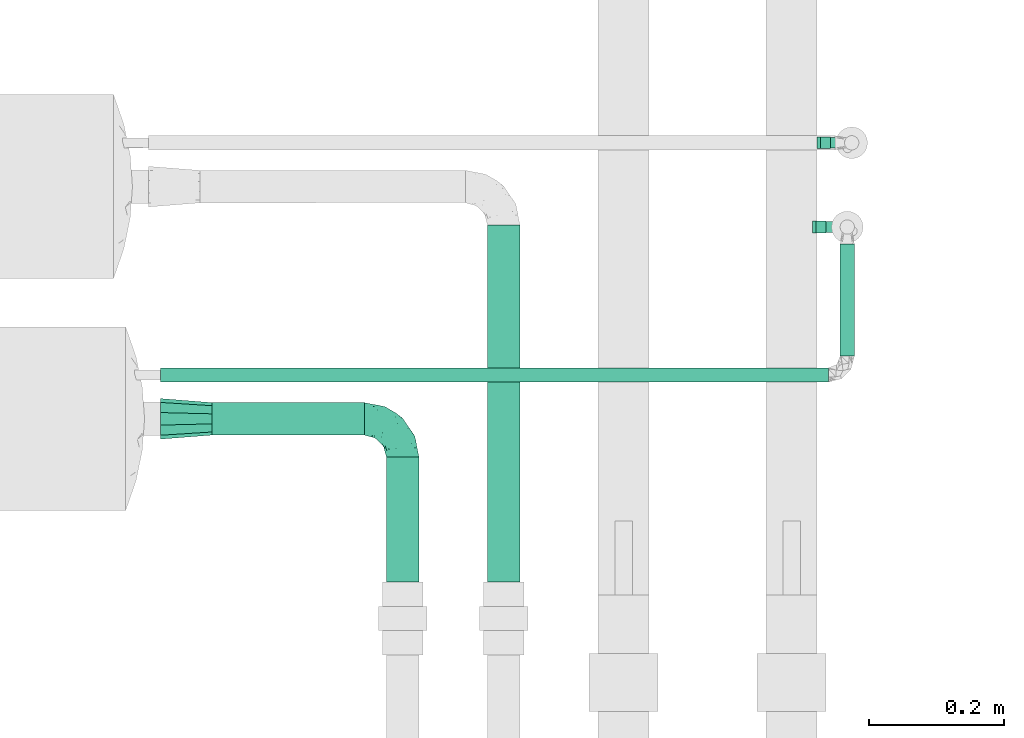
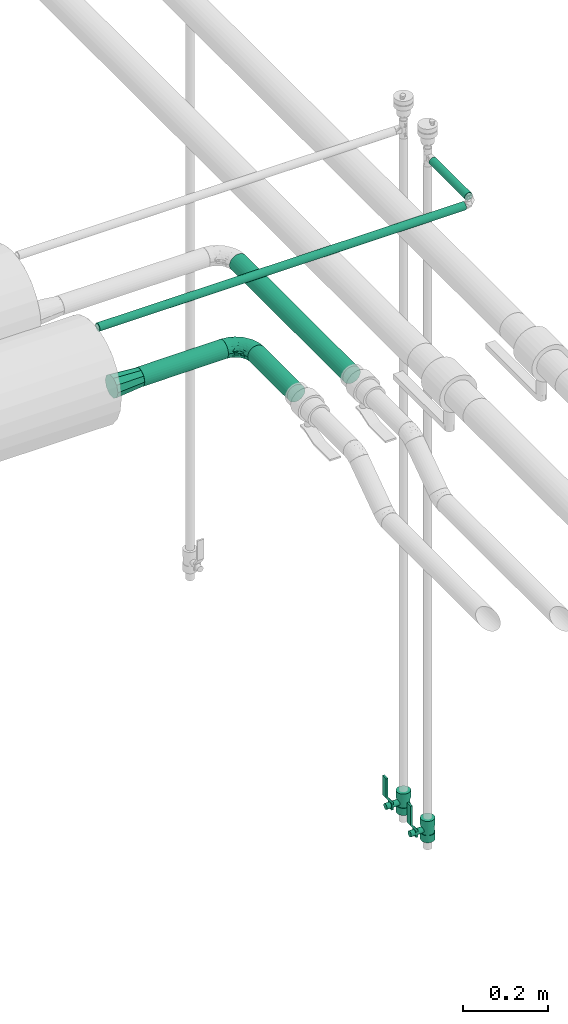
# One storey, part 588 of 824: 5 flow segments, 2 flow controllers, 2 flow fittings.
"""IFC2X3 building model written with IfcOpenShell, lengths in millimetres."""

import ifcopenshell
import ifcopenshell.guid

model = None  # the IFC model being written
_history = None  # IfcOwnerHistory: only IFC2X3 demands one
_inside = {}  # id of a spatial element -> (the spatial element, [elements in it])
_under = {}  # id of a project, library or spatial element -> (it, [spatial elements below it])
_declared = {}  # id of a project -> (the project, [libraries it declares])
_typed = {}  # id of a type object -> (the type object, [elements of that type])
_made_of = {}  # id of a material, layer set ... -> (it, [elements and type objects made of it])


def new_model(schema):
    """Start an empty IFC model of exactly this schema.

    Asked for "IFC4X3", IfcOpenShell would pick the latest addendum, in which some entities
    have other attributes; the version numbers below select the first issue.
    IFC2X3 requires an IfcOwnerHistory on every rooted entity: one is made here for all.
    """
    global model, _history
    if schema == "IFC4X3":
        model = ifcopenshell.file(schema_version=(4, 3, 0, 0))
    else:
        model = ifcopenshell.file(schema=schema)
    _inside.clear()
    _under.clear()
    _declared.clear()
    _typed.clear()
    _made_of.clear()
    _history = None
    if model.schema == "IFC2X3":
        org = make("IfcOrganization", Name="unknown")
        user = make(
            "IfcPersonAndOrganization",
            ThePerson=make("IfcPerson", FamilyName="unknown"),
            TheOrganization=org,
        )
        app = make(
            "IfcApplication",
            ApplicationDeveloper=org,
            Version="unknown",
            ApplicationFullName="unknown",
            ApplicationIdentifier="unknown",
        )
        _history = make(
            "IfcOwnerHistory",
            OwningUser=user,
            OwningApplication=app,
            ChangeAction="ADDED",
            CreationDate=0,
        )
    return model


def make(cls, **values):
    """One entity of the class cls with the attributes given. An attribute that is None is left unset."""
    return model.create_entity(
        cls, **{name: value for name, value in values.items() if value is not None}
    )


def entity(cls, *values):
    """Any entity or typed value of the class cls, its attributes in the order of the schema. None: left unset."""
    e = model.create_entity(cls)
    for i, value in enumerate(values):
        if value is not None:
            e[i] = value
    return e


def rooted(cls, **values):
    """An entity with a GlobalId (a new one), such as an element, a storey or a relation."""
    return make(cls, GlobalId=ifcopenshell.guid.new(), OwnerHistory=_history, **values)


def si_unit(unit_type, name, prefix=None):
    """IfcSIUnit, for example si_unit("LENGTHUNIT", "METRE", prefix="MILLI")."""
    return make("IfcSIUnit", UnitType=unit_type, Prefix=prefix, Name=name)


def converted_unit(unit_type, name, factor, base, dimensions=None, offset=None):
    """IfcConversionBasedUnit, such as the inch: factor (a typed value) times the base unit."""
    return make(
        "IfcConversionBasedUnit"
        if offset is None
        else "IfcConversionBasedUnitWithOffset",
        ConversionOffset=offset,
        Dimensions=None
        if dimensions is None
        else entity("IfcDimensionalExponents", *dimensions),
        UnitType=unit_type,
        Name=name,
        ConversionFactor=make(
            "IfcMeasureWithUnit", ValueComponent=factor, UnitComponent=base
        ),
    )


def derived_unit(unit_type, elements):
    """IfcDerivedUnit: a product of units, each with its exponent."""
    return make(
        "IfcDerivedUnit",
        Elements=[
            make("IfcDerivedUnitElement", Unit=unit, Exponent=power)
            for unit, power in elements
        ],
        UnitType=unit_type,
    )


def assignment(units):
    """IfcUnitAssignment: the units of a project."""
    return None if units is None else make("IfcUnitAssignment", Units=units)


def point(xyz):
    """IfcCartesianPoint."""
    return None if xyz is None else make("IfcCartesianPoint", Coordinates=xyz)


def direction(xyz):
    """IfcDirection."""
    return None if xyz is None else make("IfcDirection", DirectionRatios=xyz)


def frame(location, z_axis=None, x_axis=None):
    """IfcAxis2Placement3D, a coordinate frame: its origin and axes. An axis left out is left unset."""
    return make(
        "IfcAxis2Placement3D",
        Location=point(location),
        Axis=direction(z_axis),
        RefDirection=direction(x_axis),
    )


def frame_2d(location, x_axis=None):
    """IfcAxis2Placement2D, a coordinate frame in the plane: its origin and x axis."""
    return make(
        "IfcAxis2Placement2D", Location=point(location), RefDirection=direction(x_axis)
    )


def origin():
    """The frame at (0, 0, 0) with its axes left unset."""
    return frame((0.0, 0.0, 0.0))


def origin_2d_with_axis():
    """The frame at (0, 0) in the plane with the x axis (1, 0) written out."""
    return frame_2d((0.0, 0.0), x_axis=(1.0, 0.0))


def place(relative_to, where):
    """IfcLocalPlacement: puts the frame where relative to a parent placement (None: the world)."""
    return make(
        "IfcLocalPlacement", PlacementRelTo=relative_to, RelativePlacement=where
    )


def context(
    kind, dimensions, precision=None, world=None, true_north=None, identifier=None
):
    """IfcGeometricRepresentationContext, for example the 3D "Model" context."""
    return make(
        "IfcGeometricRepresentationContext",
        ContextIdentifier=identifier,
        ContextType=kind,
        CoordinateSpaceDimension=dimensions,
        Precision=precision,
        WorldCoordinateSystem=world,
        TrueNorth=true_north,
    )


def subcontext(parent, identifier, kind, view, scale=None):
    """IfcGeometricRepresentationSubContext, for example "Body" below "Model"."""
    return make(
        "IfcGeometricRepresentationSubContext",
        ContextIdentifier=identifier,
        ContextType=kind,
        ParentContext=parent,
        TargetScale=scale,
        TargetView=view,
    )


def project(units=None, contexts=None):
    """IfcProject with its units and contexts."""
    return rooted(
        "IfcProject",
        Name="project",
        RepresentationContexts=contexts,
        UnitsInContext=assignment(units),
    )


def spatial(cls, under=None, at=None, **own):
    """A site, building, storey or space (cls), placed at a placement, below another one or the project."""
    s = rooted(cls, ObjectPlacement=at, **own)
    if under is not None:
        _under.setdefault(under.id(), (under, []))[1].append(s)
    return s


def polyline(points):
    """IfcPolyline through the points."""
    return make("IfcPolyline", Points=[point(p) for p in points])


def profile(cls, at=None, kind="AREA", **sizes):
    """A parametric profile (cls). Its sizes go by their IFC names, for example OverallWidth=200.0."""
    return make(cls, ProfileType=kind, Position=at, **sizes)


def circle(**sizes):
    """IfcCircleProfileDef."""
    return profile("IfcCircleProfileDef", **sizes)


def outline(outer, holes=None, kind="AREA"):
    """IfcArbitraryClosedProfileDef: a profile drawn as a closed curve; with holes, ...WithVoids."""
    if holes is None:
        return make("IfcArbitraryClosedProfileDef", ProfileType=kind, OuterCurve=outer)
    return make(
        "IfcArbitraryProfileDefWithVoids",
        ProfileType=kind,
        OuterCurve=outer,
        InnerCurves=holes,
    )


def extrude(swept, where, along, depth):
    """IfcExtrudedAreaSolid: the profile swept, set in the frame where, extruded along a direction by depth."""
    return make(
        "IfcExtrudedAreaSolid",
        SweptArea=swept,
        Position=where,
        ExtrudedDirection=direction(along),
        Depth=depth,
    )


def faces_of(points, faces, orient=None, outer=None):
    """IfcFace entities. A face is a list of loops; a loop is a list of indices into points, from 0.

    orient and outer hold one flag for each loop. By default every Orientation is true, the
    first loop of a face is its IfcFaceOuterBound and the others are IfcFaceBound.
    """
    made = []
    for i, loops in enumerate(faces):
        bounds = []
        for j, loop in enumerate(loops):
            is_outer = j == 0 if outer is None else outer[i][j]
            bounds.append(
                make(
                    "IfcFaceOuterBound" if is_outer else "IfcFaceBound",
                    Bound=make("IfcPolyLoop", Polygon=[points[k] for k in loop]),
                    Orientation=True if orient is None else orient[i][j],
                )
            )
        made.append(make("IfcFace", Bounds=bounds))
    return made


def faceted_brep(points, faces, orient=None, outer=None, voids=None):
    """IfcFacetedBrep: a solid bounded by flat faces; with voids (closed shells), ...WithVoids."""
    shared = [point(p) for p in points]
    hull = make("IfcClosedShell", CfsFaces=faces_of(shared, faces, orient, outer))
    if voids is None:
        return make("IfcFacetedBrep", Outer=hull)
    return make(
        "IfcFacetedBrepWithVoids",
        Outer=hull,
        Voids=[
            make(cls, CfsFaces=faces_of(shared, fs, o, b)) for cls, fs, o, b in voids
        ],
    )


def shape(context_of_items, identifier, shape_type, items):
    """IfcShapeRepresentation: the items that make up one representation, for example the "Body"."""
    return make(
        "IfcShapeRepresentation",
        ContextOfItems=context_of_items,
        RepresentationIdentifier=identifier,
        RepresentationType=shape_type,
        Items=items,
    )


def source(mapping_origin, context_of_items, identifier, shape_type, items):
    """IfcRepresentationMap: a shape defined once, which mapped items show again and again."""
    return make(
        "IfcRepresentationMap",
        MappingOrigin=mapping_origin,
        MappedRepresentation=shape(context_of_items, identifier, shape_type, items),
    )


def transform(
    local_origin,
    x_axis=None,
    y_axis=None,
    z_axis=None,
    scale=None,
    scale2=None,
    scale3=None,
    uniform=True,
):
    """IfcCartesianTransformationOperator3D, or its non-uniform kind. x_axis, y_axis, z_axis: its Axis1, 2, 3."""
    if uniform:
        return make(
            "IfcCartesianTransformationOperator3D",
            Axis1=direction(x_axis),
            Axis2=direction(y_axis),
            LocalOrigin=point(local_origin),
            Scale=scale,
            Axis3=direction(z_axis),
        )
    return make(
        "IfcCartesianTransformationOperator3DnonUniform",
        Axis1=direction(x_axis),
        Axis2=direction(y_axis),
        LocalOrigin=point(local_origin),
        Scale=scale,
        Axis3=direction(z_axis),
        Scale2=scale2,
        Scale3=scale3,
    )


def mapped(mapping_source, mapping_target):
    """IfcMappedItem: shows the shape of a source again, moved by a transform."""
    return make(
        "IfcMappedItem", MappingSource=mapping_source, MappingTarget=mapping_target
    )


def material(Name=None, Category=None):
    """IfcMaterial."""
    return make("IfcMaterial", Name=Name, Category=Category)


def material_list(materials):
    """IfcMaterialList."""
    return make("IfcMaterialList", Materials=materials)


def made_of(thing, what):
    """Note that an element or type object is made of a material, layer set ...; save() writes the relation."""
    if what is not None:
        _made_of.setdefault(what.id(), (what, []))[1].append(thing)
    return thing


def type_object(cls, material=None, **own):
    """A type object (cls), such as IfcWallType, which elements share."""
    return made_of(rooted(cls, **own), material)


def type_shapes(of_type, sources):
    """Give a type object the sources (RepresentationMaps) that its elements show as mapped items."""
    of_type.RepresentationMaps = sources


def element(
    cls,
    number,
    at=None,
    inside=None,
    cuts=None,
    type_object=None,
    material=None,
    context=None,
    identifier="Body",
    shape_type=None,
    held_by="IfcProductDefinitionShape",
    body=None,
    shapes=None,
    **own,
):
    """One element of the class cls, such as IfcWall. Its Tag is "e" and its number.

    at: its placement. inside: the storey or other place that contains it. cuts: it is an
    opening in that element (IfcRelVoidsElement). A single representation is given by context,
    identifier, shape_type and body (its items); several are given by shapes. held_by: the class
    of the entity that holds the representations. save() writes the other relations.
    """
    e = rooted(cls, Tag="e%d" % number, ObjectPlacement=at, **own)
    if body is not None:
        shapes = [shape(context, identifier, shape_type, body)]
    if shapes is not None:
        e.Representation = make(held_by, Representations=shapes)
    if inside is not None:
        _inside.setdefault(inside.id(), (inside, []))[1].append(e)
    if cuts is not None:
        rooted(
            "IfcRelVoidsElement", RelatingBuildingElement=cuts, RelatedOpeningElement=e
        )
    if type_object is not None:
        _typed.setdefault(type_object.id(), (type_object, []))[1].append(e)
    return made_of(e, material)


def aggregate(whole, parts):
    """IfcRelAggregates: a whole, such as a stair, and the parts it consists of."""
    return rooted("IfcRelAggregates", RelatingObject=whole, RelatedObjects=parts)


def save(model, path):
    """Write the relations noted so far, then the file.

    IfcRelAggregates (storeys below a building ...), IfcRelContainedInSpatialStructure (elements
    in a storey), IfcRelDefinesByType, IfcRelAssociatesMaterial and IfcRelDeclares: one each for
    every whole, place, type object, material and project.
    """
    for whole, parts in _under.values():
        aggregate(whole, parts)
    for where, things in _inside.values():
        rooted(
            "IfcRelContainedInSpatialStructure",
            RelatedElements=things,
            RelatingStructure=where,
        )
    for kind, things in _typed.values():
        rooted("IfcRelDefinesByType", RelatedObjects=things, RelatingType=kind)
    for what, things in _made_of.values():
        rooted("IfcRelAssociatesMaterial", RelatedObjects=things, RelatingMaterial=what)
    for by, libraries in _declared.values():
        rooted("IfcRelDeclares", RelatingContext=by, RelatedDefinitions=libraries)
    model.write(path)


model = new_model("IFC2X3")

# Units and contexts
model_context = context("Model", 3, precision=0.01, world=origin(), true_north=direction((6.12303176911189e-17, 1.0)))
body_context = subcontext(model_context, "Body", "Model", "MODEL_VIEW")
ifc_project = project(units=[si_unit("LENGTHUNIT", "METRE", prefix="MILLI"), si_unit("AREAUNIT", "SQUARE_METRE"), si_unit("VOLUMEUNIT", "CUBIC_METRE"), converted_unit("PLANEANGLEUNIT", "DEGREE", entity("IfcRatioMeasure", 0.0174532925199433), si_unit("PLANEANGLEUNIT", "RADIAN"), dimensions=[0, 0, 0, 0, 0, 0, 0]), si_unit("MASSUNIT", "GRAM", prefix="KILO"), derived_unit("MASSDENSITYUNIT", [(si_unit("MASSUNIT", "GRAM", prefix="KILO"), 1), (si_unit("LENGTHUNIT", "METRE"), -3)]), derived_unit("MOMENTOFINERTIAUNIT", [(si_unit("LENGTHUNIT", "METRE"), 4)]), si_unit("TIMEUNIT", "SECOND"), si_unit("FREQUENCYUNIT", "HERTZ"), si_unit("THERMODYNAMICTEMPERATUREUNIT", "DEGREE_CELSIUS"), derived_unit("THERMALTRANSMITTANCEUNIT", [(si_unit("MASSUNIT", "GRAM", prefix="KILO"), 1), (si_unit("THERMODYNAMICTEMPERATUREUNIT", "KELVIN"), -1), (si_unit("TIMEUNIT", "SECOND"), -3)]), derived_unit("VOLUMETRICFLOWRATEUNIT", [(si_unit("LENGTHUNIT", "METRE"), 3), (si_unit("TIMEUNIT", "SECOND"), -1)]), derived_unit("MASSFLOWRATEUNIT", [(si_unit("MASSUNIT", "GRAM", prefix="KILO"), 1), (si_unit("TIMEUNIT", "SECOND"), -1)]), derived_unit("ROTATIONALFREQUENCYUNIT", [(si_unit("TIMEUNIT", "SECOND"), -1)]), si_unit("ELECTRICCURRENTUNIT", "AMPERE"), si_unit("ELECTRICVOLTAGEUNIT", "VOLT"), si_unit("POWERUNIT", "WATT"), si_unit("FORCEUNIT", "NEWTON", prefix="KILO"), si_unit("ILLUMINANCEUNIT", "LUX"), si_unit("LUMINOUSFLUXUNIT", "LUMEN"), si_unit("LUMINOUSINTENSITYUNIT", "CANDELA"), derived_unit("USERDEFINED", [(si_unit("MASSUNIT", "GRAM", prefix="KILO"), -1), (si_unit("LENGTHUNIT", "METRE"), -2), (si_unit("TIMEUNIT", "SECOND"), 3), (si_unit("LUMINOUSFLUXUNIT", "LUMEN"), 1)]), derived_unit("LINEARVELOCITYUNIT", [(si_unit("LENGTHUNIT", "METRE"), 1), (si_unit("TIMEUNIT", "SECOND"), -1)]), si_unit("PRESSUREUNIT", "PASCAL"), derived_unit("USERDEFINED", [(si_unit("LENGTHUNIT", "METRE"), -2), (si_unit("MASSUNIT", "GRAM", prefix="KILO"), 1), (si_unit("TIMEUNIT", "SECOND"), -2)]), derived_unit("LINEARFORCEUNIT", [(si_unit("MASSUNIT", "GRAM", prefix="KILO"), 1), (si_unit("LENGTHUNIT", "METRE"), 1), (si_unit("TIMEUNIT", "SECOND"), -2), (si_unit("LENGTHUNIT", "METRE"), -1)]), derived_unit("PLANARFORCEUNIT", [(si_unit("MASSUNIT", "GRAM", prefix="KILO"), 1), (si_unit("LENGTHUNIT", "METRE"), 1), (si_unit("TIMEUNIT", "SECOND"), -2), (si_unit("LENGTHUNIT", "METRE"), -2)])], contexts=[model_context])

# Site, building, storey
site_placement = place(None, origin())
site = spatial("IfcSite", under=ifc_project, at=site_placement, CompositionType="ELEMENT")
building_placement = place(site_placement, origin())
building = spatial("IfcBuilding", under=site, at=building_placement, CompositionType="ELEMENT")
storey_placement = place(building_placement, frame((0.0, 0.0, 28200.0)))
storey = spatial("IfcBuildingStorey", under=building, at=storey_placement, CompositionType="ELEMENT", Elevation=28200.0)

# Flow segments
pipe_segment_type = type_object("IfcPipeSegmentType", PredefinedType="NOTDEFINED")
flow_segment_1_placement = place(storey_placement, frame((25256.69, 14558.36, 3116.0)))
element("IfcFlowSegment", 1, at=flow_segment_1_placement, inside=storey, type_object=pipe_segment_type, context=body_context, shape_type="SweptSolid", body=[
    extrude(circle(Radius=10.65, at=origin_2d_with_axis()), frame((0.0, 12.25, 12.25), z_axis=(1.0, 0.0, 0.0), x_axis=(0.0, 1.0, 0.0)), (0.0, 0.0, 1.0), 991.985477356617),
])
flow_segment_2_placement = place(storey_placement, frame((26264.43, 14598.6, 3116.0)))
element("IfcFlowSegment", 2, at=flow_segment_2_placement, inside=storey, type_object=pipe_segment_type, context=body_context, shape_type="SweptSolid", body=[
    extrude(circle(Radius=10.65, at=origin_2d_with_axis()), frame((12.25, 0.0, 12.25), z_axis=(0.0, 1.0, 0.0), x_axis=(-1.0, 0.0, 0.0)), (0.0, 0.0, 1.0), 166.835366592849),
])
flow_segment_3_placement = place(storey_placement, frame((25332.58, 14479.89, 2973.24)))
element("IfcFlowSegment", 3, at=flow_segment_3_placement, inside=storey, type_object=pipe_segment_type, context=body_context, shape_type="SweptSolid", body=[
    extrude(circle(Radius=24.0, at=origin_2d_with_axis()), frame((0.1, 25.6, 25.6), z_axis=(0.999990523535328, 0.0, 0.00435348590675065), x_axis=(0.0, -1.0, 0.0)), (0.0, 0.0, 1.0), 226.496980574782),
])
flow_segment_4_placement = place(storey_placement, frame((25740.61, 14262.99, 2974.4)))
element("IfcFlowSegment", 4, at=flow_segment_4_placement, inside=storey, type_object=pipe_segment_type, context=body_context, shape_type="SweptSolid", body=[
    extrude(circle(Radius=24.0, at=origin_2d_with_axis()), frame((25.6, 0.0, 25.6), z_axis=(0.0, 1.0, 0.0), x_axis=(-1.0, 0.0, 0.0)), (0.0, 0.0, 1.0), 530.584662846842),
])
flow_segment_5_placement = place(storey_placement, frame((25590.58, 14262.99, 2974.4)))
element("IfcFlowSegment", 5, at=flow_segment_5_placement, inside=storey, type_object=pipe_segment_type, context=body_context, shape_type="SweptSolid", body=[
    extrude(circle(Radius=24.0, at=origin_2d_with_axis()), frame((25.6, 0.0, 25.6), z_axis=(0.0, 1.0, 0.0), x_axis=(-1.0, 0.0, 0.0)), (0.0, 0.0, 1.0), 185.4983901967),
])

# Flow controllers
ifc_material = material()
ifc_material_list = material_list([ifc_material, ifc_material, ifc_material, ifc_material, ifc_material])
valve_type = type_object("IfcValveType", PredefinedType="NOTDEFINED", material=ifc_material_list)
shared_shape_1 = source(origin(), body_context, "Body", "SweptSolid", [
    extrude(circle(Radius=17.5, at=origin_2d_with_axis()), frame((-30.5, 0.0, 0.0), z_axis=(1.0, 0.0, 0.0), x_axis=(0.0, 1.0, 0.0)), (0.0, 0.0, 1.0), 20.3333333333333),
    extrude(circle(Radius=16.0, at=origin_2d_with_axis()), frame((-10.17, 0.0, 0.0), z_axis=(1.0, 0.0, 0.0), x_axis=(0.0, 1.0, 0.0)), (0.0, 0.0, 1.0), 20.3333333333333),
    extrude(circle(Radius=17.5, at=origin_2d_with_axis()), frame((10.17, 0.0, 0.0), z_axis=(1.0, 0.0, 0.0), x_axis=(0.0, 1.0, 0.0)), (0.0, 0.0, 1.0), 20.3333333333333),
    extrude(outline(polyline([(-38.75, -5.0), (-38.75, -10.0), (-17.92, -10.0), (2.08, 5.0), (56.25, 5.0), (56.25, 10.0), (0.42, 10.0), (-19.58, -5.0), (-38.75, -5.0)])), frame((28.75, -8.75, 41.5), z_axis=(0.0, -1.0, 0.0), x_axis=(1.0, 0.0, 0.0)), (0.0, 0.0, -1.0), 17.5),
    extrude(circle(Radius=8.0, at=origin_2d_with_axis()), origin(), (0.0, 0.0, 1.0), 49.0),
])
type_shapes(valve_type, [shared_shape_1])
for number, where, z_axis, x_axis in (
    (6, (26283.3, 14915.6, 1205.0), (-1.0, 0.0, 0.0), (0.0, 0.0, 1.0)),
    (7, (26276.67, 14790.44, 1205.0), (-1.0, 0.0, 0.0), (0.0, 0.0, 1.0)),
):
    element("IfcFlowController", number, at=place(storey_placement, frame(where, z_axis=z_axis, x_axis=x_axis)), inside=storey, type_object=valve_type, material=ifc_material, context=body_context, shape_type="MappedRepresentation", body=[
        mapped(shared_shape_1, transform((0.0, 0.0, 0.0), scale=1.0)),
    ])

# Flow fittings
pipe_fitting_type_1 = type_object("IfcPipeFittingType", PredefinedType="NOTDEFINED", material=ifc_material)
shared_shape_2 = source(origin(), body_context, "Body", "Brep", [
    faceted_brep([(-57.0, 12.07, -20.91), (-57.0, 6.25, -23.33), (-57.0, 0.0, -24.15), (-57.0, -6.25, -23.33), (-57.0, -12.08, -20.91), (-57.0, -17.08, -17.08), (-57.0, -20.91, -12.08), (-57.0, -23.33, -6.25), (-57.0, -24.15, 0.0), (-57.0, -23.33, 6.25), (-57.0, -20.91, 12.07), (-57.0, -17.08, 17.08), (-57.0, -12.08, 20.91), (-57.0, -6.25, 23.33), (-57.0, 0.0, 24.15), (-57.0, 6.25, 23.33), (-57.0, 12.07, 20.91), (-57.0, 17.08, 17.08), (-57.0, 20.91, 12.07), (-57.0, 23.33, 6.25), (-57.0, 24.15, 0.0), (-57.0, 23.33, -6.25), (-57.0, 20.91, -12.08), (-57.0, 17.08, -17.08), (0.0, 57.0, -24.15), (-6.25, 57.0, -23.33), (-12.07, 57.0, -20.91), (-17.08, 57.0, -17.08), (-20.91, 57.0, -12.08), (-23.33, 57.0, -6.25), (-24.15, 57.0, 0.0), (-23.33, 57.0, 6.25), (-20.91, 57.0, 12.07), (-17.08, 57.0, 17.08), (-12.07, 57.0, 20.91), (-6.25, 57.0, 23.33), (0.0, 57.0, 24.15), (6.25, 57.0, 23.33), (12.08, 57.0, 20.91), (17.08, 57.0, 17.08), (20.91, 57.0, 12.07), (23.33, 57.0, 6.25), (24.15, 57.0, 0.0), (23.33, 57.0, -6.25), (20.91, 57.0, -12.08), (17.08, 57.0, -17.08), (12.08, 57.0, -20.91), (6.25, 57.0, -23.33), (14.9, 21.14, 6.17), (13.61, 24.64, 12.48), (6.23, 8.95, 8.98), (-41.47, -21.06, 0.0), (-41.92, -18.38, 13.72), (-24.64, -13.61, 12.48), (-37.37, -13.24, 18.15), (-6.8, -4.93, 8.18), (-21.76, -15.19, 6.22), (-12.78, -9.18, 0.0), (-37.73, -20.51, 7.75), (-7.38, 7.38, 20.24), (-23.37, -4.26, 20.42), (-11.9, -3.19, 15.86), (-42.14, -8.7, 21.82), (13.24, 37.37, 18.15), (9.33, 23.53, 16.85), (4.26, 23.37, 20.42), (2.77, 10.92, 15.55), (-29.46, 0.91, 23.52), (-44.13, 20.56, 15.69), (-39.25, 26.33, 10.88), (-49.02, 22.92, 9.96), (-34.58, 23.87, 17.15), (-15.8, 6.8, 22.81), (-8.67, 20.47, 23.88), (-18.12, 12.9, 24.08), (-48.29, 14.92, 19.65), (-44.06, -2.85, 23.78), (-9.23, 48.95, 22.58), (-3.78, 42.74, 24.07), (-40.34, 4.26, 24.09), (-44.02, 26.14, 5.46), (-44.04, 9.88, 22.74), (-4.95, 16.87, 22.52), (-2.75, 1.43, 12.5), (-25.48, 40.98, 10.71), (20.51, 37.73, 7.75), (18.38, 41.92, 13.72), (8.7, 42.14, 21.82), (-25.95, -17.97, 0.0), (2.85, 44.06, 23.78), (21.06, 41.47, 0.0), (17.97, 25.95, 0.0), (-24.04, -9.27, 17.13), (-33.26, 33.26, 5.86), (-28.55, 40.57, 0.0), (-40.57, 28.55, 0.0), (-25.29, 47.19, 4.06), (-27.01, 31.1, 16.77), (-15.7, 43.95, 19.9), (-20.27, 45.22, 15.61), (-30.53, 31.98, 12.64), (-11.28, 38.33, 22.92), (-9.97, 27.88, 24.09), (-20.15, 30.26, 21.25), (-31.25, 11.75, 23.64), (-28.75, 7.23, 24.15), (-29.53, 18.06, 22.27), (-28.44, 24.21, 20.02), (-37.55, 17.7, 20.26), (-15.88, 29.25, 22.99), (-20.82, 20.82, 23.44), (-0.91, 29.46, 23.52), (-13.5, -7.67, 12.04), (1.49, 1.56, 5.16), (8.86, 10.35, 4.59), (0.38, -0.38, 0.0), (9.18, 12.78, 0.0), (-37.37, -13.24, -18.15), (8.86, 10.35, -4.59), (-45.22, 20.27, -15.61), (-43.95, 15.7, -19.9), (-38.33, 11.28, -22.92), (-48.95, 9.23, -22.58), (-47.19, 25.29, -4.06), (-33.26, 33.26, -5.86), (18.38, 41.92, -13.72), (-30.26, 20.15, -21.25), (2.85, 44.06, -23.78), (-4.26, 40.34, -24.09), (-40.98, 25.48, -10.71), (-41.92, -18.38, -13.72), (9.25, 23.5, -16.92), (4.26, 23.37, -20.42), (13.24, 37.37, -18.15), (-37.73, -20.51, -7.75), (-11.75, 31.25, -23.64), (-7.23, 28.75, -24.15), (-12.9, 18.12, -24.08), (8.7, 42.14, -21.82), (-44.06, -2.85, -23.78), (-6.8, 15.8, -22.81), (-20.47, 8.67, -23.88), (-24.64, -13.61, -12.48), (-42.74, 3.78, -24.07), (-18.06, 29.53, -22.27), (-24.21, 28.44, -20.02), (-27.88, 9.97, -24.09), (-31.1, 27.01, -16.77), (-26.14, 44.02, -5.46), (14.9, 21.14, -6.17), (20.51, 37.73, -7.75), (-9.88, 44.04, -22.74), (-20.56, 44.13, -15.69), (-21.76, -15.19, -6.22), (-13.5, -7.67, -12.04), (-24.14, -9.76, -16.74), (-11.9, -3.19, -15.86), (-14.92, 48.29, -19.65), (-23.37, -4.26, -20.42), (-0.91, 29.46, -23.52), (-26.33, 39.25, -10.88), (-23.87, 34.58, -17.15), (-42.14, -8.7, -21.82), (-22.92, 49.02, -9.96), (13.61, 24.64, -12.48), (-31.98, 30.53, -12.64), (-16.87, 4.95, -22.52), (-17.7, 37.55, -20.26), (-29.25, 15.88, -22.99), (-20.82, 20.82, -23.44), (-29.46, 0.91, -23.52), (-7.38, 7.38, -20.24), (2.77, 10.92, -15.55), (6.23, 8.95, -8.98), (-6.8, -4.93, -8.18), (-2.81, 1.41, -12.54), (1.49, 1.56, -5.16)], [[[0, 1, 2, 3, 4, 5, 6, 7, 8, 9, 10, 11, 12, 13, 14, 15, 16, 17, 18, 19, 20, 21, 22, 23]], [[24, 25, 26, 27, 28, 29, 30, 31, 32, 33, 34, 35, 36, 37, 38, 39, 40, 41, 42, 43, 44, 45, 46, 47]], [[48, 49, 50]], [[9, 8, 51]], [[52, 53, 54]], [[55, 56, 57]], [[10, 58, 52]], [[9, 58, 10]], [[59, 60, 61]], [[54, 12, 11]], [[54, 62, 12]], [[63, 39, 38]], [[64, 65, 66]], [[62, 60, 67]], [[68, 69, 70]], [[71, 69, 68]], [[72, 73, 74]], [[16, 75, 17]], [[13, 76, 14]], [[35, 77, 78]], [[14, 79, 15]], [[17, 68, 18]], [[14, 76, 79]], [[20, 19, 80]], [[70, 19, 18]], [[81, 15, 79]], [[15, 81, 16]], [[73, 72, 82]], [[66, 83, 50]], [[32, 31, 84]], [[85, 86, 49]], [[63, 87, 65]], [[56, 58, 88]], [[36, 89, 37]], [[85, 41, 40]], [[36, 35, 78]], [[90, 41, 85]], [[40, 39, 86]], [[12, 62, 13]], [[86, 85, 40]], [[48, 85, 49]], [[85, 91, 90]], [[87, 38, 37]], [[92, 60, 54]], [[80, 69, 93]], [[93, 94, 95]], [[10, 52, 11]], [[94, 96, 30]], [[97, 98, 99]], [[80, 93, 95]], [[100, 97, 84]], [[99, 98, 33]], [[101, 102, 78]], [[103, 101, 98]], [[96, 31, 30]], [[77, 98, 101]], [[77, 35, 34]], [[34, 33, 98]], [[9, 51, 58]], [[87, 63, 38]], [[104, 105, 74]], [[106, 103, 107]], [[106, 81, 104]], [[75, 68, 17]], [[108, 107, 71]], [[33, 32, 99]], [[109, 103, 110]], [[101, 109, 102]], [[89, 78, 111]], [[53, 52, 58]], [[54, 11, 52]], [[60, 62, 54]], [[88, 58, 51]], [[76, 62, 67]], [[53, 112, 92]], [[60, 59, 72]], [[39, 63, 86]], [[49, 86, 63]], [[89, 87, 37]], [[42, 41, 90]], [[111, 82, 65]], [[111, 65, 87]], [[65, 59, 66]], [[104, 81, 79]], [[75, 81, 108]], [[32, 84, 99]], [[97, 99, 84]], [[98, 97, 103]], [[106, 107, 108]], [[74, 102, 110]], [[111, 78, 102]], [[74, 110, 104]], [[74, 67, 72]], [[61, 92, 112]], [[66, 59, 61]], [[56, 53, 58]], [[66, 50, 49]], [[61, 112, 83]], [[66, 49, 64]], [[78, 89, 36]], [[87, 89, 111]], [[62, 76, 13]], [[79, 76, 67]], [[100, 93, 69]], [[96, 93, 84]], [[55, 113, 50]], [[113, 114, 50]], [[104, 79, 105]], [[106, 104, 110]], [[20, 80, 95]], [[85, 48, 91]], [[115, 114, 113]], [[116, 91, 48]], [[70, 80, 19]], [[93, 96, 94]], [[84, 31, 96]], [[103, 106, 110]], [[81, 106, 108]], [[103, 97, 107]], [[71, 107, 97]], [[71, 97, 100]], [[108, 71, 68]], [[79, 67, 105]], [[67, 74, 105]], [[115, 113, 57]], [[112, 56, 55]], [[56, 88, 57]], [[60, 72, 67]], [[82, 72, 59]], [[65, 82, 59]], [[82, 111, 73]], [[111, 102, 73]], [[102, 74, 73]], [[81, 75, 16]], [[68, 75, 108]], [[68, 70, 18]], [[80, 70, 69]], [[98, 77, 34]], [[78, 77, 101]], [[93, 100, 84]], [[71, 100, 69]], [[102, 109, 110]], [[101, 103, 109]], [[53, 92, 54]], [[61, 60, 92]], [[56, 112, 53]], [[83, 112, 55]], [[50, 83, 55]], [[61, 83, 66]], [[49, 63, 64]], [[65, 64, 63]], [[57, 113, 55]], [[114, 115, 116]], [[116, 48, 114]], [[48, 50, 114]], [[117, 5, 4]], [[116, 115, 118]], [[119, 120, 23]], [[121, 122, 120]], [[95, 123, 20]], [[0, 23, 120]], [[124, 95, 94]], [[125, 45, 44]], [[121, 120, 126]], [[24, 127, 128]], [[22, 21, 129]], [[0, 122, 1]], [[5, 117, 130]], [[131, 132, 133]], [[134, 88, 51]], [[135, 136, 137]], [[6, 5, 130]], [[46, 138, 47]], [[139, 3, 2]], [[140, 141, 137]], [[6, 134, 7]], [[134, 130, 142]], [[143, 2, 1]], [[144, 126, 145]], [[121, 146, 143]], [[147, 120, 119]], [[94, 148, 124]], [[149, 150, 91]], [[30, 29, 148]], [[151, 25, 128]], [[27, 152, 28]], [[134, 153, 88]], [[154, 155, 156]], [[27, 26, 157]], [[151, 26, 25]], [[155, 158, 156]], [[24, 47, 127]], [[1, 122, 143]], [[138, 132, 159]], [[160, 152, 161]], [[24, 128, 25]], [[46, 133, 138]], [[162, 117, 4]], [[148, 160, 124]], [[152, 160, 163]], [[154, 142, 155]], [[45, 125, 133]], [[133, 46, 45]], [[125, 164, 133]], [[51, 7, 134]], [[42, 90, 43]], [[165, 147, 129]], [[153, 134, 142]], [[43, 150, 44]], [[162, 4, 3]], [[141, 140, 166]], [[117, 162, 158]], [[163, 29, 28]], [[43, 90, 150]], [[123, 21, 20]], [[144, 151, 135]], [[157, 152, 27]], [[167, 145, 161]], [[23, 22, 119]], [[168, 126, 169]], [[121, 168, 146]], [[139, 143, 170]], [[142, 130, 117]], [[8, 7, 51]], [[134, 6, 130]], [[139, 162, 3]], [[170, 166, 158]], [[170, 158, 162]], [[158, 171, 156]], [[44, 150, 125]], [[91, 150, 90]], [[164, 125, 150]], [[132, 138, 133]], [[127, 138, 159]], [[131, 164, 172]], [[132, 171, 140]], [[135, 151, 128]], [[157, 151, 167]], [[22, 129, 119]], [[147, 119, 129]], [[120, 147, 126]], [[144, 145, 167]], [[137, 146, 169]], [[170, 143, 146]], [[137, 169, 135]], [[137, 159, 140]], [[171, 172, 156]], [[173, 174, 175]], [[156, 175, 154]], [[174, 57, 153]], [[132, 172, 171]], [[172, 164, 173]], [[143, 139, 2]], [[162, 139, 170]], [[138, 127, 47]], [[128, 127, 159]], [[165, 124, 160]], [[123, 124, 129]], [[149, 173, 164]], [[176, 174, 173]], [[135, 128, 136]], [[144, 135, 169]], [[150, 149, 164]], [[176, 118, 115]], [[149, 91, 116]], [[30, 148, 94]], [[163, 148, 29]], [[124, 123, 95]], [[129, 21, 123]], [[126, 144, 169]], [[151, 144, 167]], [[126, 147, 145]], [[161, 145, 147]], [[161, 147, 165]], [[167, 161, 152]], [[128, 159, 136]], [[159, 137, 136]], [[154, 153, 142]], [[132, 140, 159]], [[174, 176, 57]], [[57, 88, 153]], [[166, 140, 171]], [[158, 166, 171]], [[166, 170, 141]], [[170, 146, 141]], [[146, 137, 141]], [[151, 157, 26]], [[152, 157, 167]], [[152, 163, 28]], [[148, 163, 160]], [[120, 122, 0]], [[143, 122, 121]], [[124, 165, 129]], [[161, 165, 160]], [[146, 168, 169]], [[121, 126, 168]], [[142, 117, 155]], [[158, 155, 117]], [[175, 156, 172]], [[153, 154, 174]], [[173, 175, 172]], [[174, 154, 175]], [[164, 131, 133]], [[172, 132, 131]], [[176, 173, 118]], [[57, 176, 115]], [[173, 149, 118]], [[149, 116, 118]]]),
])
type_shapes(pipe_fitting_type_1, [shared_shape_2])
flow_fitting_1_placement = place(storey_placement, frame((25616.18, 14505.49, 3000.0), z_axis=(-0.00320586404388479, 0.0, 0.999994861204663), x_axis=(0.0, 1.0, 0.0)))
element("IfcFlowFitting", 8, at=flow_fitting_1_placement, inside=storey, type_object=pipe_fitting_type_1, material=ifc_material, context=body_context, shape_type="MappedRepresentation", body=[
    mapped(shared_shape_2, transform((0.0, 0.0, 0.0), scale=1.0)),
])
pipe_fitting_type_2 = type_object("IfcPipeFittingType", PredefinedType="NOTDEFINED", material=ifc_material)
shared_shape_3 = source(origin(), body_context, "Body", "Brep", [
    faceted_brep([(76.0, -30.15, 0.0), (76.0, -28.24, -5.87), (76.0, -26.33, -11.75), (76.0, -24.39, -17.72), (76.0, -16.85, -23.2), (76.0, -9.32, -28.67), (76.0, 0.0, -28.67), (76.0, 9.32, -28.67), (76.0, 16.85, -23.2), (76.0, 24.39, -17.72), (76.0, 26.33, -11.75), (76.0, 28.24, -5.87), (76.0, 30.15, 0.0), (76.0, 28.24, 5.87), (76.0, 26.33, 11.75), (76.0, 24.39, 17.72), (76.0, 16.85, 23.2), (76.0, 9.32, 28.67), (76.0, 0.0, 28.67), (76.0, -9.32, 28.67), (76.0, -16.85, 23.2), (76.0, -24.39, 17.72), (76.0, -26.33, 11.75), (76.0, -28.24, 5.87), (0.0, -19.54, -14.2), (0.0, -21.84, -7.1), (0.0, -24.15, 0.0), (0.0, -21.84, 7.1), (0.0, -19.54, 14.2), (0.0, -13.5, 18.58), (0.0, -7.46, 22.97), (0.0, 0.0, 22.97), (0.0, 7.46, 22.97), (0.0, 13.5, 18.58), (0.0, 19.54, 14.2), (0.0, 21.84, 7.1), (0.0, 24.15, 0.0), (0.0, 21.84, -7.1), (0.0, 19.54, -14.2), (0.0, 13.5, -18.58), (0.0, 7.46, -22.97), (0.0, 0.0, -22.97), (0.0, -7.46, -22.97), (0.0, -13.5, -18.58)], [[[0, 1, 2, 3, 4, 5, 6, 7, 8, 9, 10, 11, 12, 13, 14, 15, 16, 17, 18, 19, 20, 21, 22, 23]], [[24, 25, 26, 27, 28, 29, 30, 31, 32, 33, 34, 35, 36, 37, 38, 39, 40, 41, 42, 43]], [[24, 3, 2, 1, 0, 26, 25]], [[7, 40, 39, 38, 9, 8]], [[42, 5, 4, 3, 24, 43]], [[6, 5, 42, 41, 40, 7]], [[11, 10, 9, 38, 37, 36, 12]], [[34, 15, 14, 13, 12, 36, 35]], [[19, 30, 29, 28, 21, 20]], [[32, 17, 16, 15, 34, 33]], [[18, 17, 32, 31, 30, 19]], [[23, 22, 21, 28, 27, 26, 0]]]),
])
type_shapes(pipe_fitting_type_2, [shared_shape_3])
flow_fitting_2_placement = place(storey_placement, frame((25332.68, 14505.49, 2998.83), z_axis=(-0.00776606518238528, 0.0, 0.999969843661089), x_axis=(-0.999969843661089, 0.0, -0.00776606518238528)))
element("IfcFlowFitting", 9, at=flow_fitting_2_placement, inside=storey, type_object=pipe_fitting_type_2, material=ifc_material, context=body_context, shape_type="MappedRepresentation", body=[
    mapped(shared_shape_3, transform((0.0, 0.0, 0.0), scale=1.0)),
])

save(model, "model.ifc")
